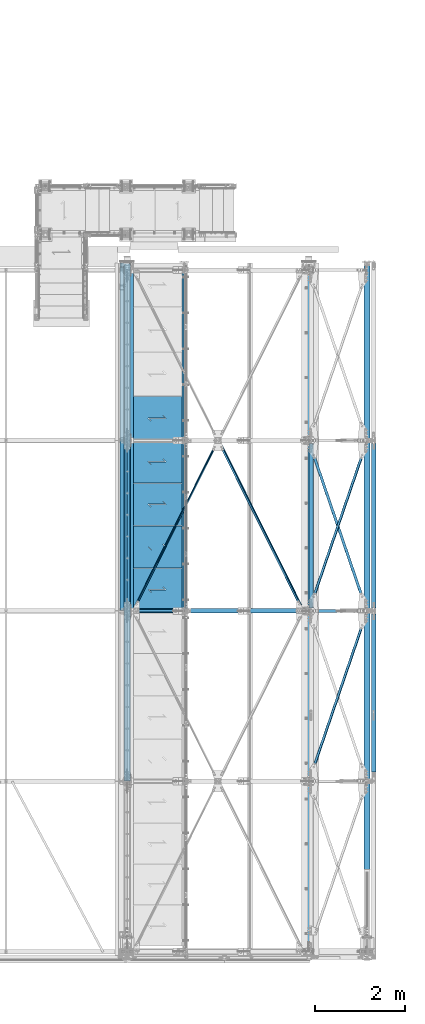
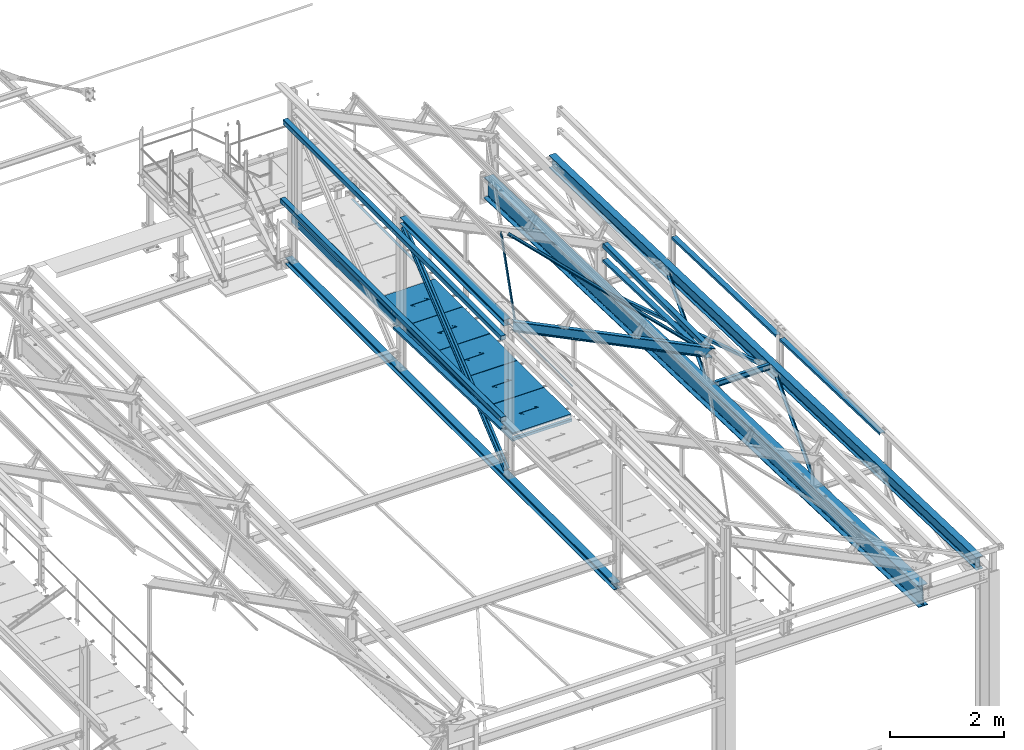
# One storey, part 56 of 496: 26 beams, 3 members, 29 elements without a shape of their own.
"""IFC2X3 building model written with IfcOpenShell, lengths in millimetres."""

from ifc_helpers import new_model, si_unit, frame, origin_with_axes, origin_2d_with_axis, place, context, subcontext, project, spatial, polyline, hollow_rectangle, hollow_circle, i_section, l_section, u_section, outline, extrude, boolean, clip, halfspace, material, type_object, element, aggregate, save


model = new_model("IFC2X3")

# Units and contexts
model_context = context("Model", 3, precision=1e-05, world=origin_with_axes())
body_context = subcontext(model_context, "Body", "Model", "MODEL_VIEW")
ifc_project = project(units=[si_unit("LENGTHUNIT", "METRE", prefix="MILLI"), si_unit("AREAUNIT", "SQUARE_METRE"), si_unit("VOLUMEUNIT", "CUBIC_METRE"), si_unit("MASSUNIT", "GRAM", prefix="KILO"), si_unit("TIMEUNIT", "SECOND"), si_unit("PLANEANGLEUNIT", "RADIAN"), si_unit("SOLIDANGLEUNIT", "STERADIAN"), si_unit("THERMODYNAMICTEMPERATUREUNIT", "DEGREE_CELSIUS"), si_unit("LUMINOUSINTENSITYUNIT", "LUMEN")], contexts=[model_context])

# Site, building, storey
site_placement = place(None, origin_with_axes())
site = spatial("IfcSite", under=ifc_project, at=site_placement, CompositionType="ELEMENT")
building_placement = place(site_placement, origin_with_axes())
building = spatial("IfcBuilding", under=site, at=building_placement, Name="Undefined", CompositionType="ELEMENT")
storey_placement = place(building_placement, origin_with_axes())
storey = spatial("IfcBuildingStorey", under=building, at=storey_placement, Name="Undefined", CompositionType="ELEMENT", Elevation=0.0)

# Assembly, beam
assembly_1_placement = place(storey_placement, origin_with_axes())
assembly_1 = element("IfcElementAssembly", 1, at=assembly_1_placement, inside=storey, Name="SUPPORT", AssemblyPlace="NOTDEFINED", PredefinedType="NOTDEFINED")
ifc_material_1 = material(Name="Undefined/S235-E24")
beam_type_1 = type_object("IfcBeamType", PredefinedType="NOTDEFINED")
beam_1_placement = place(assembly_1_placement, frame((35521.4917140446, 15280.0000894508, 8074.99999999999), z_axis=(-1.0, 0.0, 0.0), x_axis=(0.0, -1.0, 0.0)))
beam_1 = element("IfcBeam", 2, at=beam_1_placement, type_object=beam_type_1, material=ifc_material_1, Name="SUPPORT", context=body_context, shape_type="SweptSolid", body=[
    extrude(l_section(Depth=50.0, Width=50.0, Thickness=5.0, FilletRadius=7.0, EdgeRadius=3.5, at=origin_2d_with_axis()), frame((7675.0000889974, 0.0, 0.0), z_axis=(-1.0, 0.0, 0.0), x_axis=(0.0, -1.0, 0.0)), (0.0, 0.0, 1.0), 7675.0),
])
aggregate(assembly_1, [beam_1])

assembly_2_placement = place(storey_placement, origin_with_axes())
assembly_2 = element("IfcElementAssembly", 3, at=assembly_2_placement, inside=storey, AssemblyPlace="NOTDEFINED", PredefinedType="NOTDEFINED")
beam_2_placement = place(assembly_2_placement, frame((36317.9926938519, 11401.2120833738, 9504.82868148117), z_axis=(0.441221071222121, 0.0, 0.897398443451739), x_axis=(0.435090922885268, -0.87460523476945, -0.213919545943613)))
beam_2 = element("IfcBeam", 4, at=beam_2_placement, type_object=beam_type_1, material=ifc_material_1, context=body_context, shape_type="Clipping", body=[
    clip(clip(extrude(l_section(Depth=50.0, Width=50.0, Thickness=5.0, FilletRadius=7.0, EdgeRadius=3.5, at=origin_2d_with_axis()), frame((4267.3908831968, 5.92219451700071e-14, 0.0), z_axis=(-1.0, 0.0, 0.0), x_axis=(0.0, -1.0, 0.0)), (0.0, 0.0, 1.0), 4189.97), halfspace(frame((4208.92568695467, -25.0001615405272, -24.9987599295564), z_axis=(-1.0, 0.0, 0.0), x_axis=(0.0, 1.0, 0.0)), True)), halfspace(frame((135.890671518767, 25.0000024141336, -24.9993826775753), z_axis=(-1.0, 0.0, 0.0), x_axis=(0.0, 0.0, 1.0)), False)),
])
aggregate(assembly_2, [beam_2])

assembly_3_placement = place(storey_placement, origin_with_axes())
assembly_3 = element("IfcElementAssembly", 5, at=assembly_3_placement, inside=storey, AssemblyPlace="NOTDEFINED", PredefinedType="NOTDEFINED")
beam_3_placement = place(assembly_3_placement, frame((34423.6781423303, 7601.21209454312, 10436.2000510982), z_axis=(0.441221071222121, 0.0, 0.897398443451739), x_axis=(0.435090896953333, 0.874605247906247, -0.213919544977068)))
beam_3 = element("IfcBeam", 6, at=beam_3_placement, type_object=beam_type_1, material=ifc_material_1, context=body_context, shape_type="Clipping", body=[
    clip(clip(extrude(l_section(Depth=50.0, Width=50.0, Thickness=5.0, FilletRadius=7.0, EdgeRadius=3.5, at=origin_2d_with_axis()), frame((4262.41864156879, -1.18305882911529e-13, 1.18305882911529e-13), z_axis=(-1.0, 0.0, 0.0), x_axis=(0.0, -1.0, 0.0)), (0.0, 0.0, 1.0), 4180.02), halfspace(frame((4208.92661872934, 25.0000011876982, -24.9994224854781), z_axis=(-1.0, 0.0, 0.0), x_axis=(0.0, 0.0, 1.0)), True)), halfspace(frame((135.891484918182, -25.0000570368429, -24.9999963573027), z_axis=(1.0, 0.0, 0.0), x_axis=(0.0, 0.0, 1.0)), True)),
])
aggregate(assembly_3, [beam_3])

assembly_4_placement = place(storey_placement, origin_with_axes())
assembly_4 = element("IfcElementAssembly", 7, at=assembly_4_placement, inside=storey, AssemblyPlace="NOTDEFINED", PredefinedType="NOTDEFINED")
beam_type_2 = type_object("IfcBeamType", PredefinedType="NOTDEFINED")
beam_4_placement = place(assembly_4_placement, frame((39627.1613893665, 7596.0134115589, 7655.20904241501), z_axis=(0.946212867827137, 0.323385100940919, -0.0101629349981538), x_axis=(-0.323544755417773, 0.945745955238383, -0.0297216990074912)))
beam_4 = element("IfcBeam", 8, at=beam_4_placement, type_object=beam_type_2, material=ifc_material_1, context=body_context, shape_type="Clipping", body=[
    clip(clip(extrude(l_section(Depth=60.0, Width=60.0, Thickness=6.0, FilletRadius=8.0, EdgeRadius=4.0, at=origin_2d_with_axis()), frame((3750.95319410642, 9.35522168025355e-13, 7.53643561628779e-12), z_axis=(-1.0, 0.0, 0.0), x_axis=(0.0, -1.0, 0.0)), (0.0, 0.0, 1.0), 3483.91), halfspace(frame((3710.26468355594, 60.0022534992841, -30.0000080019381), z_axis=(-1.0, 0.0, 0.0), x_axis=(0.0, 1.0, 0.0)), True)), halfspace(frame((307.727514055397, 59.9989420064503, 29.9999672658596), z_axis=(1.0, 0.0, 0.0), x_axis=(0.0, 1.0, 0.0)), True)),
])
aggregate(assembly_4, [beam_4])

assembly_5_placement = place(storey_placement, origin_with_axes())
assembly_5 = element("IfcElementAssembly", 9, at=assembly_5_placement, inside=storey, AssemblyPlace="NOTDEFINED", PredefinedType="NOTDEFINED")
beam_5_placement = place(assembly_5_placement, frame((38332.8386386971, 7598.08651945775, 7721.17641887513), z_axis=(-0.946212870484427, 0.323385093165564, -0.0101629350051891), x_axis=(0.32354466896783, 0.945745967905964, -0.0297222369970447)))
beam_5 = element("IfcBeam", 10, at=beam_5_placement, type_object=beam_type_2, material=ifc_material_1, context=body_context, shape_type="Clipping", body=[
    clip(clip(extrude(l_section(Depth=60.0, Width=60.0, Thickness=6.0, FilletRadius=8.0, EdgeRadius=4.0, at=origin_2d_with_axis()), frame((3749.34946230756, -1.81898940354586e-12, 7.25807138172068e-12), z_axis=(-1.0, 0.0, 0.0), x_axis=(0.0, -1.0, 0.0)), (0.0, 0.0, 1.0), 3480.71), halfspace(frame((3710.26467476458, -60.0022405918999, -30.0000246817799), z_axis=(1.0, 0.0, 0.0), x_axis=(-8.13000000285402e-07, -0.999999999999581, 4.20999999948846e-07)), False)), halfspace(frame((307.727505635925, -59.9989526559521, 29.9999720679625), z_axis=(-1.0, 0.0, 0.0), x_axis=(-8.13000000285402e-07, -0.999999999999581, 4.20999999948846e-07)), False)),
])
aggregate(assembly_5, [beam_5])

assembly_6_placement = place(storey_placement, origin_with_axes())
assembly_6 = element("IfcElementAssembly", 11, at=assembly_6_placement, inside=storey, AssemblyPlace="NOTDEFINED", PredefinedType="NOTDEFINED")
beam_6_placement = place(assembly_6_placement, frame((38332.8386379685, 3798.08647045583, 7840.59014189747), z_axis=(-0.946212870484427, 0.323385093165564, -0.0101629350051891), x_axis=(0.323544720976448, 0.945746017931154, -0.0297200789978366)))
beam_6 = element("IfcBeam", 12, at=beam_6_placement, type_object=beam_type_2, material=ifc_material_1, context=body_context, shape_type="Clipping", body=[
    clip(clip(extrude(l_section(Depth=60.0, Width=60.0, Thickness=6.0, FilletRadius=8.0, EdgeRadius=4.0, at=origin_2d_with_axis()), frame((3749.34910549761, -9.09494701772928e-13, 3.90245034776361e-14), z_axis=(-1.0, 0.0, 0.0), x_axis=(0.0, -1.0, 0.0)), (0.0, 0.0, 1.0), 3480.71), halfspace(frame((3710.26460788765, -59.9991249984223, -29.9999532908187), z_axis=(0.999999999997803, 2.09200000135276e-06, 1.31999999817392e-07), x_axis=(1.15500000027281e-06, -0.999999999999333, 0.0)), False)), halfspace(frame((307.727696913613, -60.0042480640313, 30.0000435082766), z_axis=(-0.99999999999782, -2.08799998896818e-06, 0.0), x_axis=(1.15500000027281e-06, -0.999999999999333, 0.0)), False)),
])
aggregate(assembly_6, [beam_6])

assembly_7_placement = place(storey_placement, origin_with_axes())
assembly_7 = element("IfcElementAssembly", 13, at=assembly_7_placement, inside=storey, Name="LISSE", AssemblyPlace="NOTDEFINED", PredefinedType="NOTDEFINED")
beam_type_3 = type_object("IfcBeamType", PredefinedType="NOTDEFINED")
beam_7_placement = place(assembly_7_placement, frame((34163.5001162871, 7602.95853913206, 8291.3293909634), z_axis=(1.0, 0.0, 0.0), x_axis=(0.0, 0.999506445341009, -0.0314144190107172)))
beam_7 = element("IfcBeam", 14, at=beam_7_placement, type_object=beam_type_3, material=ifc_material_1, Name="LISSE", context=body_context, shape_type="SweptSolid", body=[
    extrude(u_section(Depth=100.0, FlangeWidth=50.0, WebThickness=4.0, FlangeThickness=4.0, at=origin_2d_with_axis()), frame((3791.87643071007, 0.0, 0.0), z_axis=(-1.0, 0.0, 0.0), x_axis=(0.0, -1.0, 0.0)), (0.0, 0.0, 1.0), 3791.88),
])
aggregate(assembly_7, [beam_7])

assembly_8_placement = place(storey_placement, origin_with_axes())
assembly_8 = element("IfcElementAssembly", 15, at=assembly_8_placement, inside=storey, Name="LISSE", AssemblyPlace="NOTDEFINED", PredefinedType="NOTDEFINED")
beam_8_placement = place(assembly_8_placement, frame((38380.0000000087, 7600.0, 8291.42237510326), z_axis=(1.0, 0.0, 0.0), x_axis=(0.0, 0.999506445341009, -0.0314144190107172)))
beam_8 = element("IfcBeam", 16, at=beam_8_placement, type_object=beam_type_3, material=ifc_material_1, Name="LISSE", context=body_context, shape_type="Clipping", body=[
    clip(clip(extrude(u_section(Depth=100.0, FlangeWidth=50.0, WebThickness=4.0, FlangeThickness=4.0, at=origin_2d_with_axis()), frame((3738.43154409699, 2.59405798515091e-14, 0.0), z_axis=(-1.0, 0.0, 0.0), x_axis=(0.0, -1.0, 0.0)), (0.0, 0.0, 1.0), 3674.99), halfspace(frame((3731.98221168591, 154.697322046104, 49.9999999913198), z_axis=(-0.999506472307554, -0.0314135610096736, 0.0), x_axis=(0.0, 0.0, 1.0)), True)), halfspace(frame((63.7935542847008, 39.4064997178375, 49.9999999913198), z_axis=(-0.999506472307554, -0.0314135610096736, 0.0), x_axis=(0.0, 0.0, 1.0)), False)),
])
aggregate(assembly_8, [beam_8])

assembly_9_placement = place(storey_placement, origin_with_axes())
assembly_9 = element("IfcElementAssembly", 17, at=assembly_9_placement, inside=storey, Name="LISSE", AssemblyPlace="NOTDEFINED", PredefinedType="NOTDEFINED")
beam_9_placement = place(assembly_9_placement, frame((39775.0000000087, 7599.20357783162, 8291.42237510326), z_axis=(1.0, 0.0, 0.0), x_axis=(0.0, 0.999506556345274, -0.0314108870109058)))
beam_9 = element("IfcBeam", 18, at=beam_9_placement, type_object=beam_type_3, material=ifc_material_1, Name="LISSE", context=body_context, shape_type="Clipping", body=[
    clip(clip(extrude(u_section(Depth=100.0, FlangeWidth=50.0, WebThickness=4.0, FlangeThickness=4.0, at=origin_2d_with_axis()), frame((3739.22774866341, 0.0, 0.0), z_axis=(-1.0, 0.0, 0.0), x_axis=(0.0, -1.0, 0.0)), (0.0, 0.0, 1.0), 3674.99), halfspace(frame((3732.77880328997, 154.708769574983, 49.9999999913198), z_axis=(-0.999506560367823, -0.0314107590115635, 0.0), x_axis=(0.0, 0.0, 1.0)), True)), halfspace(frame((64.5897267400605, 39.4312840025614, 49.9999999913198), z_axis=(-0.999506560367823, -0.0314107590115635, 0.0), x_axis=(0.0, 0.0, 1.0)), False)),
])
aggregate(assembly_9, [beam_9])

assembly_10_placement = place(storey_placement, origin_with_axes())
assembly_10 = element("IfcElementAssembly", 19, at=assembly_10_placement, inside=storey, Name="LISSE", AssemblyPlace="NOTDEFINED", PredefinedType="NOTDEFINED")
beam_10_placement = place(assembly_10_placement, frame((39775.0000000007, 3798.76352446486, 8410.85601504986), z_axis=(1.0, 0.0, 0.0), x_axis=(0.0, 0.999506556345274, -0.0314108870109058)))
beam_10 = element("IfcBeam", 20, at=beam_10_placement, type_object=beam_type_3, material=ifc_material_1, Name="LISSE", context=body_context, shape_type="Clipping", body=[
    clip(clip(extrude(u_section(Depth=100.0, FlangeWidth=50.0, WebThickness=4.0, FlangeThickness=4.0, at=origin_2d_with_axis()), frame((3739.66801927717, 0.0, 0.0), z_axis=(-1.0, 0.0, 0.0), x_axis=(0.0, -1.0, 0.0)), (0.0, 0.0, 1.0), 3536.42), halfspace(frame((3736.9701407992, 35.3478853300021, 49.9999999992579), z_axis=(-0.999506560367823, -0.0314107590115635, 0.0), x_axis=(0.0, 0.0, 1.0)), True)), halfspace(frame((203.720015756056, 35.5605322468346, 49.9999999992579), z_axis=(0.999506560367823, 0.0314107590115786, 0.0), x_axis=(0.0, 0.0, 1.0)), True)),
])
aggregate(assembly_10, [beam_10])

assembly_11_placement = place(storey_placement, origin_with_axes())
assembly_11 = element("IfcElementAssembly", 21, at=assembly_11_placement, inside=storey, Name="LISSE", AssemblyPlace="NOTDEFINED", PredefinedType="NOTDEFINED")
beam_type_4 = type_object("IfcBeamType", PredefinedType="NOTDEFINED")
beam_11_placement = place(assembly_11_placement, frame((34163.5000004361, 7604.99999901158, 10244.999999999), z_axis=(0.0, 0.0, -1.0), x_axis=(0.0, 1.0, 0.0)))
beam_11 = element("IfcBeam", 22, at=beam_11_placement, type_object=beam_type_4, material=ifc_material_1, Name="LISSE", context=body_context, shape_type="SweptSolid", body=[
    extrude(hollow_rectangle(XDim=100.0, YDim=100.0, WallThickness=4.0, InnerFilletRadius=4.0, OuterFilletRadius=8.0, at=origin_2d_with_axis()), frame((7664.99999999271, 0.0, 0.0), z_axis=(-1.0, 0.0, 0.0), x_axis=(0.0, -1.0, 0.0)), (0.0, 0.0, 1.0), 7665.0),
])
aggregate(assembly_11, [beam_11])

assembly_12_placement = place(storey_placement, origin_with_axes())
assembly_12 = element("IfcElementAssembly", 23, at=assembly_12_placement, inside=storey, Name="LISSE", AssemblyPlace="NOTDEFINED", PredefinedType="NOTDEFINED")
beam_12_placement = place(assembly_12_placement, frame((34163.5, 7605.0, 8500.0), z_axis=(0.0, 0.0, 1.0), x_axis=(0.0, 1.0, 0.0)))
beam_12 = element("IfcBeam", 24, at=beam_12_placement, type_object=beam_type_4, material=ifc_material_1, Name="LISSE", context=body_context, shape_type="SweptSolid", body=[
    extrude(hollow_rectangle(XDim=100.0, YDim=100.0, WallThickness=4.0, InnerFilletRadius=4.0, OuterFilletRadius=8.0, at=origin_2d_with_axis()), frame((7755.0, 0.0, 0.0), z_axis=(-1.0, 0.0, 0.0), x_axis=(0.0, -1.0, 0.0)), (0.0, 0.0, 1.0), 7755.0),
])
aggregate(assembly_12, [beam_12])

assembly_13_placement = place(storey_placement, origin_with_axes())
assembly_13 = element("IfcElementAssembly", 25, at=assembly_13_placement, inside=storey, Name="LISSE", AssemblyPlace="NOTDEFINED", PredefinedType="NOTDEFINED")
beam_13_placement = place(assembly_13_placement, frame((38380.0, 7670.0, 8500.0), z_axis=(0.0, 0.0, 1.0), x_axis=(0.0, 1.0, 0.0)))
beam_13 = element("IfcBeam", 26, at=beam_13_placement, type_object=beam_type_4, material=ifc_material_1, Name="LISSE", context=body_context, shape_type="SweptSolid", body=[
    extrude(hollow_rectangle(XDim=100.0, YDim=100.0, WallThickness=4.0, InnerFilletRadius=4.0, OuterFilletRadius=8.0, at=origin_2d_with_axis()), frame((3660.0, 0.0, 0.0), z_axis=(-1.0, 0.0, 0.0), x_axis=(0.0, -1.0, 0.0)), (0.0, 0.0, 1.0), 3660.0),
])
aggregate(assembly_13, [beam_13])

assembly_14_placement = place(storey_placement, origin_with_axes())
assembly_14 = element("IfcElementAssembly", 27, at=assembly_14_placement, inside=storey, AssemblyPlace="NOTDEFINED", PredefinedType="NOTDEFINED")
beam_type_5 = type_object("IfcBeamType", PredefinedType="NOTDEFINED")
beam_14_placement = place(assembly_14_placement, frame((35536.4915949059, 12385.0003192566, 8115.0), z_axis=(0.0, 0.0, 1.0), x_axis=(-1.0, 0.0, 0.0)))
beam_14 = element("IfcBeam", 28, at=beam_14_placement, type_object=beam_type_5, material=ifc_material_1, context=body_context, shape_type="CSG", body=[
    boolean("DIFFERENCE", extrude(outline(polyline([(0.0, 0.0), (1179.99169921875, 0.0), (1179.99169921875, 980.0), (-9.39995516091585e-07, 980.0), (0.0, 0.0)])), frame((0.0, 0.0, -15.0), z_axis=(0.0, 0.0, 1.0), x_axis=(1.0, 0.0, 0.0)), (0.0, 0.0, 1.0), 30.0), extrude(outline(polyline([(0.0, 0.0), (9.99999999997453, 6.91215973347425e-11), (10.0000000004329, 75.8578643791443), (282.842712400121, -196.984848017997), (282.842712400743, -96.9848480190813), (272.842712400776, -96.9848480191613), (272.842712400299, -172.842712398218), (0.0, 100.0), (0.0, 0.0)])), frame((724.286946489367, 555.710676888644, -17.5), z_axis=(0.0, 0.0, 1.0), x_axis=(-0.707106781186457, -0.707106781186639, 0.0)), (0.0, 0.0, 1.0), 35.0)),
])
aggregate(assembly_14, [beam_14])

assembly_15_placement = place(storey_placement, origin_with_axes())
assembly_15 = element("IfcElementAssembly", 29, at=assembly_15_placement, inside=storey, AssemblyPlace="NOTDEFINED", PredefinedType="NOTDEFINED")
beam_type_6 = type_object("IfcBeamType", PredefinedType="NOTDEFINED")
beam_15_placement = place(assembly_15_placement, frame((35536.4915949059, 8545.00031925659, 8115.0), z_axis=(0.0, 0.0, 1.0), x_axis=(-1.0, 0.0, 0.0)))
beam_15 = element("IfcBeam", 30, at=beam_15_placement, type_object=beam_type_6, material=ifc_material_1, context=body_context, shape_type="CSG", body=[
    boolean("DIFFERENCE", extrude(outline(polyline([(0.0, 0.0), (1179.99169921875, 0.0), (1179.99169921875, 940.0), (-9.39995516091585e-07, 940.0), (0.0, 0.0)])), frame((0.0, 0.0, -15.0), z_axis=(0.0, 0.0, 1.0), x_axis=(1.0, 0.0, 0.0)), (0.0, 0.0, 1.0), 30.0), extrude(outline(polyline([(0.0, 0.0), (9.99999999997453, 6.91215973347425e-11), (10.0000000004329, 75.8578643791443), (282.842712400121, -196.984848017997), (282.842712400743, -96.9848480190813), (272.842712400776, -96.9848480191613), (272.842712400299, -172.842712398218), (0.0, 100.0), (0.0, 0.0)])), frame((724.286946489367, 535.710676888644, -17.5), z_axis=(0.0, 0.0, 1.0), x_axis=(-0.707106781186457, -0.707106781186639, 0.0)), (0.0, 0.0, 1.0), 35.0)),
])
aggregate(assembly_15, [beam_15])

assembly_16_placement = place(storey_placement, origin_with_axes())
assembly_16 = element("IfcElementAssembly", 31, at=assembly_16_placement, inside=storey, AssemblyPlace="NOTDEFINED", PredefinedType="NOTDEFINED")
beam_16_placement = place(assembly_16_placement, frame((35536.4916006059, 9495.00031925659, 8115.0), z_axis=(0.0, 0.0, 1.0), x_axis=(-1.0, 0.0, 0.0)))
beam_16 = element("IfcBeam", 32, at=beam_16_placement, type_object=beam_type_6, material=ifc_material_1, context=body_context, shape_type="CSG", body=[
    boolean("DIFFERENCE", extrude(outline(polyline([(0.0, 0.0), (1179.99169921875, 0.0), (1179.99169921875, 940.0), (-9.39995516091585e-07, 940.0), (0.0, 0.0)])), frame((0.0, 0.0, -15.0), z_axis=(0.0, 0.0, 1.0), x_axis=(1.0, 0.0, 0.0)), (0.0, 0.0, 1.0), 30.0), extrude(outline(polyline([(0.0, 0.0), (9.99999999997453, 6.91215973347425e-11), (10.0000000004329, 75.8578643791443), (282.842712400121, -196.984848017997), (282.842712400743, -96.9848480190813), (272.842712400776, -96.9848480191613), (272.842712400299, -172.842712398218), (0.0, 100.0), (0.0, 0.0)])), frame((724.286946489367, 535.710676888644, -17.5), z_axis=(0.0, 0.0, 1.0), x_axis=(-0.707106781186457, -0.707106781186639, 0.0)), (0.0, 0.0, 1.0), 35.0)),
])
aggregate(assembly_16, [beam_16])

assembly_17_placement = place(storey_placement, origin_with_axes())
assembly_17 = element("IfcElementAssembly", 33, at=assembly_17_placement, inside=storey, AssemblyPlace="NOTDEFINED", PredefinedType="NOTDEFINED")
beam_17_placement = place(assembly_17_placement, frame((35536.4916063059, 10445.0003192566, 8115.0), z_axis=(0.0, 0.0, 1.0), x_axis=(-1.0, 0.0, 0.0)))
beam_17 = element("IfcBeam", 34, at=beam_17_placement, type_object=beam_type_6, material=ifc_material_1, context=body_context, shape_type="CSG", body=[
    boolean("DIFFERENCE", extrude(outline(polyline([(0.0, 0.0), (1179.99169921875, 0.0), (1179.99169921875, 940.0), (-9.39995516091585e-07, 940.0), (0.0, 0.0)])), frame((0.0, 0.0, -15.0), z_axis=(0.0, 0.0, 1.0), x_axis=(1.0, 0.0, 0.0)), (0.0, 0.0, 1.0), 30.0), extrude(outline(polyline([(0.0, 0.0), (9.99999999997453, 6.91215973347425e-11), (10.0000000004329, 75.8578643791443), (282.842712400121, -196.984848017997), (282.842712400743, -96.9848480190813), (272.842712400776, -96.9848480191613), (272.842712400299, -172.842712398218), (0.0, 100.0), (0.0, 0.0)])), frame((724.286946489367, 535.710676888644, -17.5), z_axis=(0.0, 0.0, 1.0), x_axis=(-0.707106781186457, -0.707106781186639, 0.0)), (0.0, 0.0, 1.0), 35.0)),
])
aggregate(assembly_17, [beam_17])

assembly_18_placement = place(storey_placement, origin_with_axes())
assembly_18 = element("IfcElementAssembly", 35, at=assembly_18_placement, inside=storey, AssemblyPlace="NOTDEFINED", PredefinedType="NOTDEFINED")
beam_18_placement = place(assembly_18_placement, frame((35536.4916120059, 11395.0003240258, 8115.0), z_axis=(0.0, 0.0, 1.0), x_axis=(-1.0, 0.0, 0.0)))
beam_18 = element("IfcBeam", 36, at=beam_18_placement, type_object=beam_type_6, material=ifc_material_1, context=body_context, shape_type="CSG", body=[
    boolean("DIFFERENCE", extrude(outline(polyline([(0.0, 0.0), (1179.99169921875, 0.0), (1179.99169921875, 940.0), (-9.39995516091585e-07, 940.0), (0.0, 0.0)])), frame((0.0, 0.0, -15.0), z_axis=(0.0, 0.0, 1.0), x_axis=(1.0, 0.0, 0.0)), (0.0, 0.0, 1.0), 30.0), extrude(outline(polyline([(0.0, 0.0), (9.99999999997453, 6.91215973347425e-11), (10.0000000004329, 75.8578643791443), (282.842712400121, -196.984848017997), (282.842712400743, -96.9848480190813), (272.842712400776, -96.9848480191613), (272.842712400299, -172.842712398218), (0.0, 100.0), (0.0, 0.0)])), frame((724.286946489367, 535.710676888644, -17.5), z_axis=(0.0, 0.0, 1.0), x_axis=(-0.707106781186457, -0.707106781186639, 0.0)), (0.0, 0.0, 1.0), 35.0)),
])
aggregate(assembly_18, [beam_18])

assembly_19_placement = place(storey_placement, origin_with_axes())
assembly_19 = element("IfcElementAssembly", 37, at=assembly_19_placement, inside=storey, Name="MAIN COURANTE", AssemblyPlace="NOTDEFINED", PredefinedType="NOTDEFINED")
beam_type_7 = type_object("IfcBeamType", PredefinedType="NOTDEFINED")
beam_19_placement = place(assembly_19_placement, frame((35593.9917197329, 11344.9999942251, 8673.79999937563), z_axis=(0.0, 0.0, 1.0), x_axis=(0.0, -1.0, 0.0)))
beam_19 = element("IfcBeam", 38, at=beam_19_placement, type_object=beam_type_7, material=ifc_material_1, Name="LISSE", context=body_context, shape_type="SweptSolid", body=[
    extrude(hollow_circle(Radius=13.44999981, WallThickness=2.0, at=origin_2d_with_axis()), frame((3690.00000000169, 3.69000323827281e-24, 0.0), z_axis=(-1.0, 0.0, 0.0), x_axis=(0.0, -1.0, 0.0)), (0.0, 0.0, 1.0), 3690.0),
])
aggregate(assembly_19, [beam_19])

assembly_20_placement = place(storey_placement, origin_with_axes())
assembly_20 = element("IfcElementAssembly", 39, at=assembly_20_placement, inside=storey, AssemblyPlace="NOTDEFINED", PredefinedType="NOTDEFINED")
ifc_material_2 = material(Name="Undefined/S275-E28")
beam_type_8 = type_object("IfcBeamType", Name="HEA140", PredefinedType="NOTDEFINED")
beam_20_placement = place(assembly_20_placement, frame((34283.5, 11325.0, 10489.5), z_axis=(0.0, 0.0, 1.0), x_axis=(0.0, -1.0, 0.0)))
beam_20 = element("IfcBeam", 40, at=beam_20_placement, type_object=beam_type_8, material=ifc_material_2, ObjectType="HEA140", context=body_context, shape_type="SweptSolid", body=[
    extrude(i_section(OverallWidth=140.0, OverallDepth=133.0, WebThickness=5.5, FlangeThickness=8.5, FilletRadius=12.0, at=origin_2d_with_axis()), frame((3650.0, 0.0, 0.0), z_axis=(-1.0, 0.0, 0.0), x_axis=(0.0, -1.0, 0.0)), (0.0, 0.0, 1.0), 3650.0),
])
aggregate(assembly_20, [beam_20])

assembly_21_placement = place(storey_placement, origin_with_axes())
assembly_21 = element("IfcElementAssembly", 41, at=assembly_21_placement, inside=storey, AssemblyPlace="NOTDEFINED", PredefinedType="NOTDEFINED")
beam_21_placement = place(assembly_21_placement, frame((34279.9999999998, 15350.000000027, 7183.50000000037), z_axis=(0.0, 0.0, 1.0), x_axis=(0.0, -1.0, 0.0)))
beam_21 = element("IfcBeam", 42, at=beam_21_placement, type_object=beam_type_8, material=ifc_material_2, ObjectType="HEA140", context=body_context, shape_type="SweptSolid", body=[
    extrude(i_section(OverallWidth=140.0, OverallDepth=133.0, WebThickness=5.5, FlangeThickness=8.5, FilletRadius=12.0, at=origin_2d_with_axis()), frame((11545.0000000265, 0.0, 0.0), z_axis=(-1.0, 0.0, 0.0), x_axis=(0.0, -1.0, 0.0)), (0.0, 0.0, 1.0), 11545.0),
])
aggregate(assembly_21, [beam_21])

assembly_22_placement = place(storey_placement, origin_with_axes())
assembly_22 = element("IfcElementAssembly", 43, at=assembly_22_placement, inside=storey, AssemblyPlace="NOTDEFINED", PredefinedType="NOTDEFINED")
beam_type_9 = type_object("IfcBeamType", PredefinedType="NOTDEFINED")
beam_22_placement = place(assembly_22_placement, frame((34381.4999458406, 7605.00000239701, 8025.0), z_axis=(0.0, 0.0, 1.0), x_axis=(0.0, 1.0, 0.0)))
beam_22 = element("IfcBeam", 44, at=beam_22_placement, type_object=beam_type_9, material=ifc_material_1, context=body_context, shape_type="SweptSolid", body=[
    extrude(u_section(Depth=150.0, FlangeWidth=70.0, WebThickness=5.0, FlangeThickness=5.0, at=origin_2d_with_axis()), frame((7755.00015882436, 0.0, 0.0), z_axis=(-1.0, 0.0, 0.0), x_axis=(0.0, -1.0, 0.0)), (0.0, 0.0, 1.0), 7755.0),
])
aggregate(assembly_22, [beam_22])

# Assembly, member
assembly_23_placement = place(storey_placement, origin_with_axes())
assembly_23 = element("IfcElementAssembly", 45, at=assembly_23_placement, inside=storey, AssemblyPlace="NOTDEFINED", PredefinedType="NOTDEFINED")
member_type_1 = type_object("IfcMemberType", Name="UPN80", PredefinedType="NOTDEFINED")
member_1_placement = place(assembly_23_placement, frame((34307.4999999937, 7599.99999999989, 7250.0), z_axis=(0.0, -0.64093909508163, 0.76759173809776), x_axis=(0.0, 0.767591736292195, 0.640939097243985)))
member_1 = element("IfcMember", 46, at=member_1_placement, type_object=member_type_1, material=ifc_material_2, ObjectType="UPN80", context=body_context, shape_type="Clipping", body=[
    clip(clip(extrude(u_section(Depth=80.0, FlangeWidth=45.0, WebThickness=6.0, FlangeThickness=8.0, FilletRadius=8.0, EdgeRadius=4.0, FlangeSlope=0.0798299857122373, at=origin_2d_with_axis()), frame((4910.05224962439, 0.0, 1.04649042213807e-12), z_axis=(-1.0, 0.0, 0.0), x_axis=(0.0, -1.0, 0.0)), (0.0, 0.0, 1.0), 4869.56), halfspace(frame((4830.5483535527, 27.5000000297296, 39.9999985196043), z_axis=(1.0, 0.0, 0.0), x_axis=(0.0, 1.0, 0.0)), False)), halfspace(frame((119.999999989826, 27.5000000297296, 39.9999985196016), z_axis=(1.0, 0.0, 0.0), x_axis=(0.0, 1.0, 0.0)), True)),
])
aggregate(assembly_23, [member_1])

assembly_24_placement = place(storey_placement, origin_with_axes())
assembly_24 = element("IfcElementAssembly", 47, at=assembly_24_placement, inside=storey, AssemblyPlace="NOTDEFINED", PredefinedType="NOTDEFINED")
member_2_placement = place(assembly_24_placement, frame((34252.5000000274, 11400.0000003543, 10422.9999997217), z_axis=(0.0, -0.64093909508163, 0.76759173809776), x_axis=(0.0, -0.76759173809776, -0.64093909508163)))
member_2 = element("IfcMember", 48, at=member_2_placement, type_object=member_type_1, material=ifc_material_2, ObjectType="UPN80", context=body_context, shape_type="Clipping", body=[
    clip(clip(extrude(u_section(Depth=80.0, FlangeWidth=45.0, WebThickness=6.0, FlangeThickness=8.0, FilletRadius=8.0, EdgeRadius=4.0, FlangeSlope=0.0798299857122373, at=origin_2d_with_axis()), frame((4910.05224962439, 0.0, 1.04649042213807e-12), z_axis=(-1.0, 0.0, 0.0), x_axis=(0.0, -1.0, 0.0)), (0.0, 0.0, 1.0), 4869.56), halfspace(frame((4830.5483535527, 27.5000000297296, 39.9999985196043), z_axis=(-1.0, 0.0, 0.0), x_axis=(0.0, -1.0, 0.0)), True)), halfspace(frame((119.999999989826, 27.5000000297296, 39.9999985196016), z_axis=(-1.0, 0.0, 0.0), x_axis=(0.0, -1.0, 0.0)), False)),
])
aggregate(assembly_24, [member_2])

# Assembly, beam
assembly_25_placement = place(storey_placement, origin_with_axes())
assembly_25 = element("IfcElementAssembly", 49, at=assembly_25_placement, inside=storey, Name="TRAVERSE", AssemblyPlace="NOTDEFINED", PredefinedType="NOTDEFINED")
beam_type_10 = type_object("IfcBeamType", Name="IPE450", PredefinedType="NOTDEFINED")
beam_23_placement = place(assembly_25_placement, frame((38330.0000000007, 73.5353861613257, 7822.57984998251), z_axis=(0.0, -0.031410887010906, -0.999506556345274), x_axis=(0.0, 0.999506556345274, -0.0314108870109058)))
beam_23 = element("IfcBeam", 50, at=beam_23_placement, type_object=beam_type_10, material=ifc_material_2, Name="TRAVERSE", ObjectType="IPE450", context=body_context, shape_type="Clipping", body=[
    clip(extrude(i_section(OverallWidth=190.0, OverallDepth=450.0, WebThickness=9.399999619, FlangeThickness=14.60000038, FilletRadius=21.0, at=origin_2d_with_axis()), frame((15316.9552171171, 0.0, 0.0), z_axis=(-1.0, 0.0, 0.0), x_axis=(0.0, -1.0, 0.0)), (0.0, 0.0, 1.0), 15316.96), halfspace(frame((15276.9354795832, -95.0, -225.000007845978), z_axis=(0.999506560367824, 0.0, -0.0314107590115582), x_axis=(0.0314107590115582, 0.0, 0.999506560367824)), False)),
])
aggregate(assembly_25, [beam_23])

assembly_26_placement = place(storey_placement, origin_with_axes())
assembly_26 = element("IfcElementAssembly", 51, at=assembly_26_placement, inside=storey, AssemblyPlace="NOTDEFINED", PredefinedType="NOTDEFINED")
beam_type_11 = type_object("IfcBeamType", PredefinedType="NOTDEFINED")
beam_24_placement = place(assembly_26_placement, frame((34357.991943003, 7600.0, 8015.0), z_axis=(0.0, -1.0, 0.0), x_axis=(1.0, 0.0, 0.0)))
beam_24 = element("IfcBeam", 52, at=beam_24_placement, type_object=beam_type_11, material=ifc_material_1, context=body_context, shape_type="SweptSolid", body=[
    extrude(hollow_rectangle(XDim=60.0, YDim=60.0, WallThickness=3.0, InnerFilletRadius=3.0, OuterFilletRadius=6.0, at=origin_2d_with_axis()), frame((1181.99977105896, 0.0, 0.0), z_axis=(-1.0, 0.0, 0.0), x_axis=(0.0, -1.0, 0.0)), (0.0, 0.0, 1.0), 1182.0),
])
aggregate(assembly_26, [beam_24])

assembly_27_placement = place(storey_placement, origin_with_axes())
assembly_27 = element("IfcElementAssembly", 53, at=assembly_27_placement, inside=storey, AssemblyPlace="NOTDEFINED", PredefinedType="NOTDEFINED")
beam_type_12 = type_object("IfcBeamType", Name="IPE120", PredefinedType="NOTDEFINED")
beam_25_placement = place(assembly_27_placement, frame((38430.0, 7599.99999999992, 7751.13072963871), z_axis=(0.0, 0.031410887010906, 0.999506556345274), x_axis=(1.0, 0.0, 0.0)))
beam_25 = element("IfcBeam", 54, at=beam_25_placement, type_object=beam_type_12, material=ifc_material_2, ObjectType="IPE120", context=body_context, shape_type="SweptSolid", body=[
    extrude(i_section(OverallWidth=64.0, OverallDepth=120.0, WebThickness=4.400000095, FlangeThickness=6.300000191, FilletRadius=7.0, at=origin_2d_with_axis()), frame((1125.00000000002, 0.0, 0.0), z_axis=(-1.0, 0.0, 0.0), x_axis=(0.0, -1.0, 0.0)), (0.0, 0.0, 1.0), 1125.0),
])
aggregate(assembly_27, [beam_25])

assembly_28_placement = place(storey_placement, origin_with_axes())
assembly_28 = element("IfcElementAssembly", 55, at=assembly_28_placement, inside=storey, Name="TRAVERSE", AssemblyPlace="NOTDEFINED", PredefinedType="NOTDEFINED")
beam_type_13 = type_object("IfcBeamType", Name="IPE270", PredefinedType="NOTDEFINED")
beam_26_placement = place(assembly_28_placement, frame((39630.0000000007, -4.24045248748951, 7915.0666143496), z_axis=(0.0, -0.031410887010906, -0.999506556345274), x_axis=(0.0, 0.999506556345274, -0.0314108870109058)))
beam_26 = element("IfcBeam", 56, at=beam_26_placement, type_object=beam_type_13, material=ifc_material_2, Name="TRAVERSE", ObjectType="IPE270", context=body_context, shape_type="Clipping", body=[
    clip(clip(extrude(i_section(OverallWidth=135.0, OverallDepth=270.0, WebThickness=6.599999905, FlangeThickness=10.19999981, FilletRadius=15.0, at=origin_2d_with_axis()), frame((15397.5977849943, 0.0, 0.0), z_axis=(-1.0, 0.0, 0.0), x_axis=(0.0, -1.0, 0.0)), (0.0, 0.0, 1.0), 15066.76), halfspace(frame((15367.5829676994, -67.5, -135.0), z_axis=(0.999506560367824, 0.0, -0.0314107590115582), x_axis=(0.0314107590115582, 0.0, 0.999506560367824)), False)), halfspace(frame((336.246093787946, -7.13043846189976e-10, -100.611253845233), z_axis=(-0.999506560367824, 0.0, 0.0314107590115593), x_axis=(0.0, 1.0, 0.0)), False)),
])
aggregate(assembly_28, [beam_26])

# Assembly, member
assembly_29_placement = place(storey_placement, origin_with_axes())
assembly_29 = element("IfcElementAssembly", 57, at=assembly_29_placement, inside=storey, Name="TRAVERSE SHED", AssemblyPlace="NOTDEFINED", PredefinedType="NOTDEFINED")
member_type_2 = type_object("IfcMemberType", Name="IPE200", PredefinedType="NOTDEFINED")
member_3_placement = place(assembly_29_placement, frame((34305.8779065378, 7599.9999999968, 10466.2601489394), z_axis=(0.441221071222121, 0.0, 0.897398443451739), x_axis=(0.897398510539058, 0.0, -0.441220934773362)))
member_3 = element("IfcMember", 58, at=member_3_placement, type_object=member_type_2, material=ifc_material_2, Name="TRAVERSE SHED", ObjectType="IPE200", context=body_context, shape_type="Clipping", body=[
    clip(clip(extrude(i_section(OverallWidth=100.0, OverallDepth=200.0, WebThickness=5.599999905, FlangeThickness=8.5, FilletRadius=12.0, at=origin_2d_with_axis()), frame((4652.25219148987, 0.0, 0.0), z_axis=(-1.0, 0.0, 0.0), x_axis=(0.0, -1.0, 0.0)), (0.0, 0.0, 1.0), 4763.89), halfspace(frame((4421.9420250161, -7599.9999999968, -100.0), z_axis=(0.848887783899296, 0.0, -0.528573107854099), x_axis=(0.0, -1.0, 0.0)), False)), halfspace(frame((5.83309030194869, 3.19837843542485e-09, 102.867936075316), z_axis=(-0.89739851053906, 0.0, -0.44122093477336), x_axis=(0.0, -1.0, 0.0)), False)),
])
aggregate(assembly_29, [member_3])

save(model, "model.ifc")
